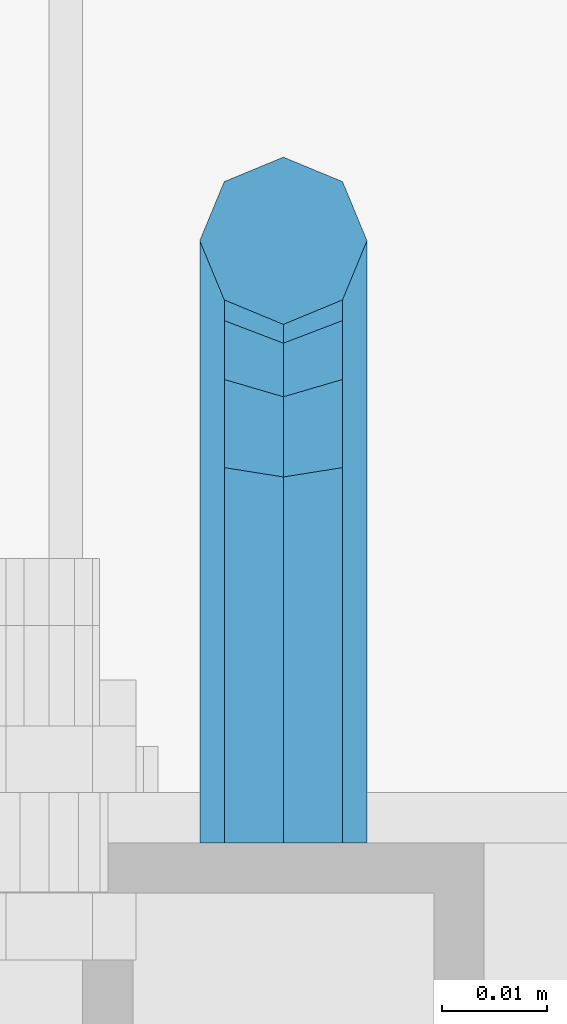
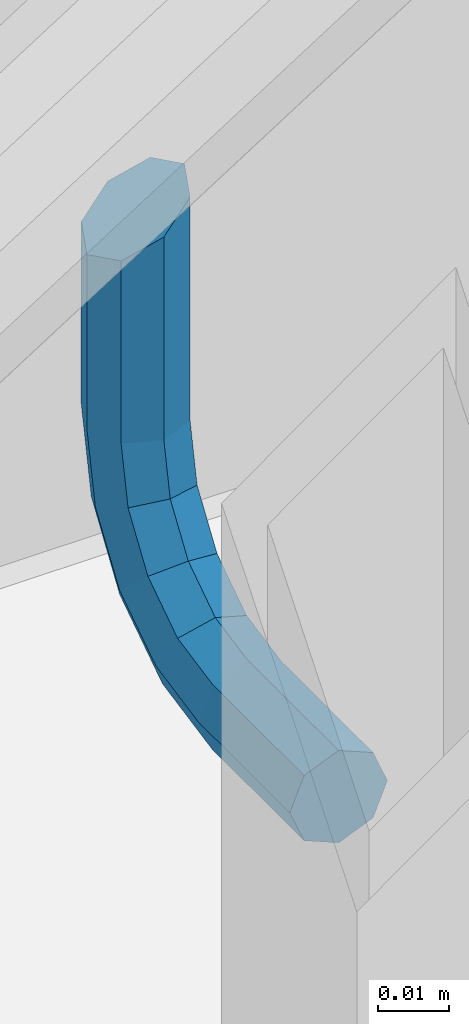
# One storey, part 1185 of 1876: 1 beam, 1 element without a shape of its own.
"""IFC2X3 building model written with IfcOpenShell, lengths in millimetres."""

from ifc_helpers import new_model, si_unit, frame, origin_with_axes, place, context, subcontext, project, spatial, faceted_brep, material, type_object, element, aggregate, save


model = new_model("IFC2X3")

# Units and contexts
model_context = context("Model", 3, precision=1e-05, world=origin_with_axes())
body_context = subcontext(model_context, "Body", "Model", "MODEL_VIEW")
ifc_project = project(units=[si_unit("LENGTHUNIT", "METRE", prefix="MILLI"), si_unit("AREAUNIT", "SQUARE_METRE"), si_unit("VOLUMEUNIT", "CUBIC_METRE"), si_unit("MASSUNIT", "GRAM", prefix="KILO"), si_unit("TIMEUNIT", "SECOND"), si_unit("PLANEANGLEUNIT", "RADIAN"), si_unit("SOLIDANGLEUNIT", "STERADIAN"), si_unit("THERMODYNAMICTEMPERATUREUNIT", "DEGREE_CELSIUS"), si_unit("LUMINOUSINTENSITYUNIT", "LUMEN")], contexts=[model_context])

# Site, building, storey
site_placement = place(None, origin_with_axes())
site = spatial("IfcSite", under=ifc_project, at=site_placement, CompositionType="ELEMENT")
building_placement = place(site_placement, origin_with_axes())
building = spatial("IfcBuilding", under=site, at=building_placement, Name="Undefined", CompositionType="ELEMENT")
storey_placement = place(building_placement, origin_with_axes())
storey = spatial("IfcBuildingStorey", under=building, at=storey_placement, Name="Undefined", CompositionType="ELEMENT", Elevation=0.0)

# Assembly, beam
assembly_placement = place(storey_placement, origin_with_axes())
assembly = element("IfcElementAssembly", 1, at=assembly_placement, inside=storey, Name="RAIL", AssemblyPlace="NOTDEFINED", PredefinedType="RIGID_FRAME")
ifc_material = material(Name="STEEL/A36")
beam_type = type_object("IfcBeamType", PredefinedType="NOTDEFINED")
beam_placement = place(assembly_placement, frame((3911.60006207481, -5715.00000114554, 1743.99072298841), z_axis=(1.0, 0.0, 0.0), x_axis=(0.0, 1.0, 0.0)))
beam = element("IfcBeam", 2, at=beam_placement, type_object=beam_type, material=ifc_material, Name="BRACKET", context=body_context, shape_type="Brep", body=[
    faceted_brep([(0.0, -5.61266007566822, 5.61266007566883), (0.0, 0.0, 7.9375), (0.0, 5.61266007566822, 5.61266007566883), (0.0, 7.9375, 0.0), (0.0, 5.61266007566822, -5.61266007566883), (0.0, 0.0, -7.9375), (0.0, -5.61266007566822, -5.61266007566883), (0.0, -7.9375, 0.0), (25.7500019073486, -5.6126600756694, -5.61266007566974), (25.7500019073486, -7.93750000000102, -1.81898940354586e-12), (25.7500019073486, -5.61266007566837, 5.61266007566746), (25.7500019073486, 6.82121026329696e-13, 7.93750000000045), (25.7500019073486, 5.6126600756694, 5.61266007566928), (25.7500019073486, 7.93750000000102, 9.09494701772928e-13), (25.7500019073486, 5.61266007566837, -5.61266007566837), (25.7500019073486, -6.82121026329696e-13, -7.93750000000091), (37.7662607879083, 2.39017891888352, -7.93750166859718), (39.9141330299508, -2.79524175511915, -5.61265950959933), (40.803811282025, -4.94311113920139, 1.49169682117645e-06), (39.9141340902152, -2.79523647837323, 5.6126606417356), (37.7662622873477, 2.39018638132939, 7.937498331401), (35.6183900453052, 7.57560705533251, 5.61265617240315), (34.728711793231, 9.7234764394143, -4.82889299746603e-06), (35.6183889850417, 7.57560177858613, -5.61266397893178), (43.9844035873093, 13.1655940203409, -5.61266788133162), (47.9531531815637, 9.19684280310457, -7.93750642036139), (42.3404944911981, 14.8095070346781, -8.37947573018027e-06), (43.9844055464218, 13.1655998976785, 5.6126522700024), (47.9531559521674, 9.19685111491481, 7.93749357963588), (51.9219055464218, 5.22809989767848, 5.61265504060611), (53.565814642534, 3.58418688334177, -4.46125068265246e-06), (51.9219035873093, 5.2280940203409, -5.61266511072881), (54.7598170657875, 19.3837351967577, -7.93751353188054), (59.9452393627726, 17.2358645776962, -5.61267349341051), (49.5743958290659, 21.5316086226071, -5.61267372168732), (47.4265250864628, 22.4212897326429, -1.36932976602111e-05), (49.5743983887696, 21.5316153987928, 5.61264642964761), (54.7598206857547, 19.3837447797314, 7.93748646811673), (59.9452419224763, 17.235871353882, 5.61264665792351), (62.0931126650794, 16.3461902438462, -1.33704661493539e-05), (62.7626602162454, 31.3999957002966, -5.61268338145874), (65.0875015258789, 31.3999996185225, -2.19204903260106e-05), (57.1499995667664, 31.399994077316, -7.93752192048851), (51.5373400649087, 31.3999957002989, -5.61268061085502), (49.2125015258789, 31.3999996185239, -1.99613778022467e-05), (51.5373428355124, 31.4000035367485, 5.61263954047809), (57.1500034849914, 31.4000051597295, 7.93747807950785), (62.7626629868482, 31.4000035367467, 5.61263676987437), (65.0875015258789, 66.3398661827996, -4.63121787106502e-05), (62.7626620592855, 69.9005606306541, 5.6126108200142), (57.1500021229667, 71.3754489730973, 7.93745017245874), (51.5373419079488, 69.9005612114365, 5.61261173549065), (49.2125015258789, 66.3398666704393, -4.55435210824362e-05), (51.5373408209025, 62.7791718437898, -5.61270327280181), (57.1500005856506, 61.3042833925019, -7.93754279681616), (62.7626609722383, 62.779171045318, -5.61270453141788)], [[[0, 1, 2, 3, 4, 5, 6, 7]], [[7, 6, 8, 9]], [[0, 7, 9, 10]], [[1, 0, 10, 11]], [[2, 1, 11, 12]], [[3, 2, 12, 13]], [[4, 3, 13, 14]], [[5, 4, 14, 15]], [[6, 5, 15, 8]], [[8, 15, 16, 17]], [[9, 8, 17, 18]], [[10, 9, 18, 19]], [[11, 10, 19, 20]], [[12, 11, 20, 21]], [[13, 12, 21, 22]], [[14, 13, 22, 23]], [[15, 14, 23, 16]], [[23, 24, 25, 16]], [[22, 26, 24, 23]], [[21, 27, 26, 22]], [[20, 28, 27, 21]], [[19, 29, 28, 20]], [[18, 30, 29, 19]], [[17, 31, 30, 18]], [[16, 25, 31, 17]], [[25, 32, 33, 31]], [[24, 34, 32, 25]], [[26, 35, 34, 24]], [[27, 36, 35, 26]], [[28, 37, 36, 27]], [[29, 38, 37, 28]], [[30, 39, 38, 29]], [[31, 33, 39, 30]], [[33, 40, 41, 39]], [[32, 42, 40, 33]], [[34, 43, 42, 32]], [[35, 44, 43, 34]], [[36, 45, 44, 35]], [[37, 46, 45, 36]], [[38, 47, 46, 37]], [[39, 41, 47, 38]], [[47, 41, 48, 49]], [[46, 47, 49, 50]], [[45, 46, 50, 51]], [[44, 45, 51, 52]], [[43, 44, 52, 53]], [[42, 43, 53, 54]], [[40, 42, 54, 55]], [[41, 40, 55, 48]], [[54, 53, 52, 51, 50, 49, 48, 55]]]),
])
aggregate(assembly, [beam])

save(model, "model.ifc")
